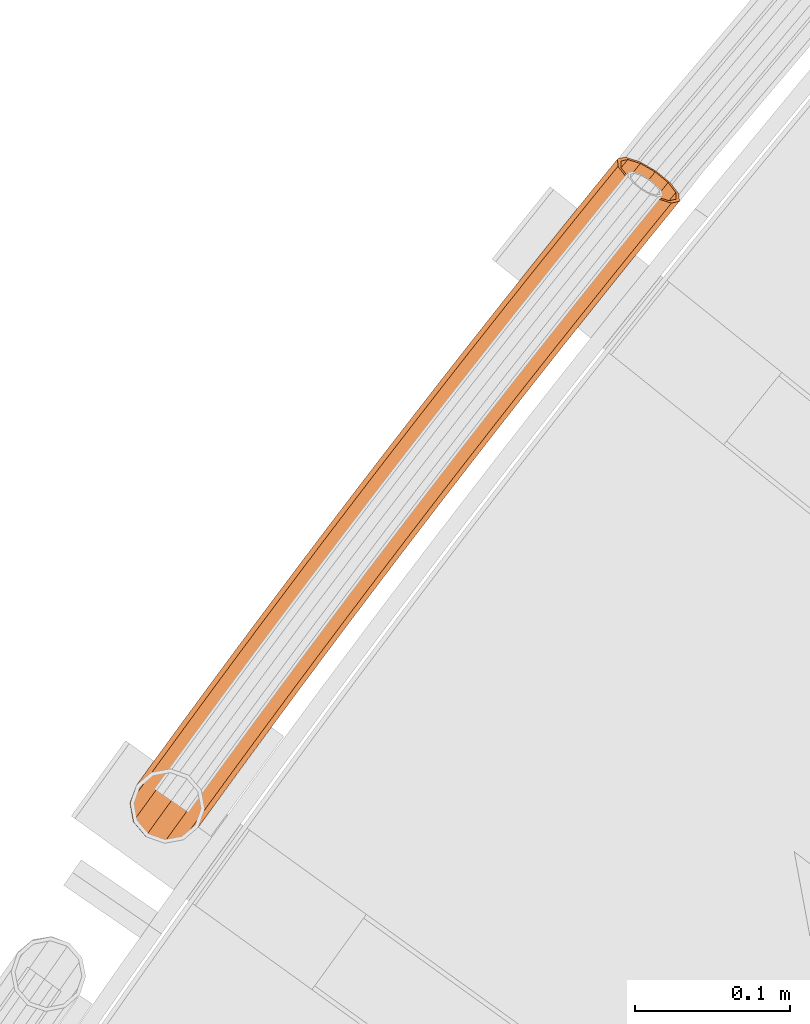
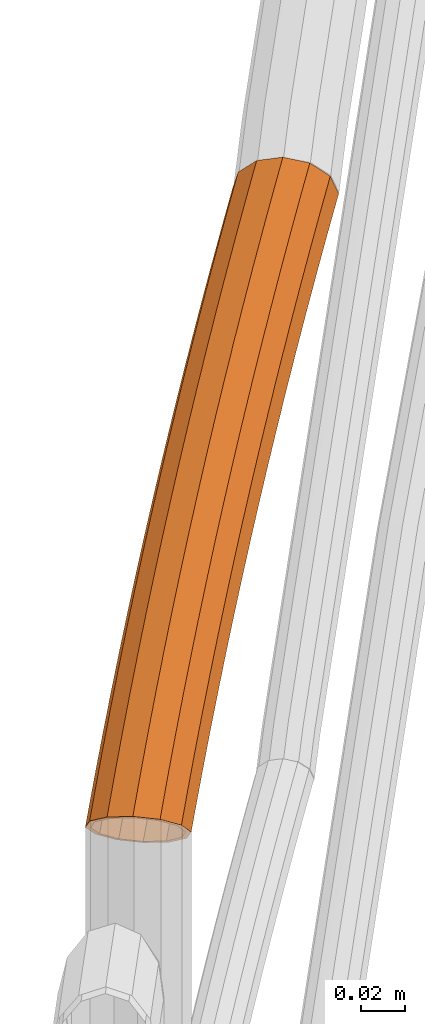
# One storey, part 65 of 126: 1 proxy.
"""IFC2X3 building model written with IfcOpenShell, lengths in millimetres."""

from ifc_helpers import new_model, si_unit, origin, origin_with_axes, place, context, project, spatial, faceted_brep, material, element, save


model = new_model("IFC2X3")

# Units and contexts
context_of_model_1 = context(None, 3, precision=0.1, world=origin())
context_of_model_2 = context(None, 3, precision=0.1, world=origin())
ifc_project = project(units=[si_unit("LENGTHUNIT", "METRE", prefix="MILLI"), si_unit("AREAUNIT", "SQUARE_METRE", prefix="CENTI"), si_unit("VOLUMEUNIT", "CUBIC_METRE", prefix="CENTI"), si_unit("MASSUNIT", "GRAM", prefix="KILO")], contexts=[context_of_model_1, context_of_model_2])

# Site, building, storey
site_placement = place(None, origin_with_axes())
site = spatial("IfcSite", under=ifc_project, at=site_placement, CompositionType="ELEMENT")
building_placement = place(site_placement, origin_with_axes())
building = spatial("IfcBuilding", under=site, at=building_placement, CompositionType="ELEMENT")
storey_placement = place(building_placement, origin_with_axes())
storey = spatial("IfcBuildingStorey", under=building, at=storey_placement, CompositionType="ELEMENT")

# Proxy
ifc_material = material(Name="S235JRG2")
proxy_placement = place(storey_placement, origin_with_axes())
element("IfcBuildingElementProxy", 1, at=proxy_placement, inside=storey, material=ifc_material, Name="HANDLAUF", context=context_of_model_2, shape_type="Brep", body=[
    faceted_brep([(824.6093, 13181.756, 9410.6145), (821.5899, 13177.553, 9410.6145), (828.7136, 13178.797, 9405.5548), (814.8145, 13188.818, 9413.85), (809.7472, 13181.763, 9413.85), (805.0197, 13195.879, 9410.6145), (801.6805, 13191.231, 9410.6145), (800.27, 13199.304, 9404.7592), (806.0336, 13195.148, 9408.4494), (803.9743, 13192.282, 9408.4494), (803.1045, 13197.26, 9404.8385), (814.8145, 13188.818, 9411.35), (811.206, 13183.794, 9411.35), (823.5954, 13182.487, 9408.4494), (821.8227, 13180.019, 9408.4494), (826.0049, 13180.75, 9405.479), (813.4129, 13228.076, 9389.7), (816.0308, 13226.175, 9377.625), (813.7213, 13222.983, 9377.625), (803.9729, 13215.031, 9389.7), (819.1362, 13223.92, 9373.787), (849.8756, 13201.594, 9377.625), (848.2081, 13199.29, 9377.625), (847.513, 13203.31, 9374.7051), (852.4935, 13199.693, 9389.7), (843.7948, 13187.672, 9389.7), (849.8756, 13201.594, 9401.775), (834.0464, 13179.719, 9401.775), (842.7233, 13206.789, 9410.6145), (832.9532, 13213.885, 9413.85), (823.1831, 13220.981, 9410.6145), (799.5596, 13203.413, 9401.775), (816.0308, 13226.175, 9401.775), (815.4357, 13226.607, 9389.7), (817.7826, 13224.903, 9400.525), (802.0776, 13203.199, 9400.525), (806.0341, 13213.615, 9389.7), (824.1945, 13220.246, 9408.4494), (832.9532, 13213.885, 9411.35), (841.7119, 13207.523, 9408.4494), (848.1238, 13202.867, 9400.525), (832.9944, 13181.959, 9400.525), (850.4707, 13201.162, 9389.7), (841.7337, 13189.088, 9389.7), (848.1238, 13202.867, 9378.875), (845.6901, 13199.504, 9378.875), (844.6755, 13205.371, 9374.6133), (817.7826, 13224.903, 9378.875), (814.7733, 13220.744, 9378.875), (821.8289, 13221.964, 9373.8741), (831.6887, 13253.148, 9389.7), (834.2999, 13251.237, 9377.625), (841.434, 13246.018, 9368.7855), (826.2076, 13225.13, 9368.7855), (851.1793, 13238.888, 9365.55), (838.0706, 13220.905, 9365.55), (860.9246, 13231.758, 9368.7855), (846.1204, 13211.449, 9368.7855), (868.0587, 13226.539, 9377.625), (870.6699, 13224.628, 9389.7), (868.0587, 13226.539, 9401.775), (860.9246, 13231.758, 9410.6145), (851.1793, 13238.888, 9413.85), (841.434, 13246.018, 9410.6145), (834.2999, 13251.237, 9401.775), (833.7064, 13251.672, 9389.7), (836.0473, 13249.959, 9400.525), (842.4428, 13245.28, 9408.4494), (851.1793, 13238.888, 9411.35), (859.9158, 13232.496, 9408.4494), (866.3113, 13227.817, 9400.525), (868.6523, 13226.104, 9389.7), (866.3113, 13227.817, 9378.875), (843.8138, 13210.407, 9370.9506), (859.9158, 13232.496, 9370.9506), (851.1793, 13238.888, 9368.05), (836.5974, 13218.884, 9368.05), (842.4428, 13245.28, 9370.9506), (825.9624, 13222.671, 9370.9506), (836.0473, 13249.959, 9378.875), (850.0519, 13278.155, 9389.7), (852.6564, 13276.236, 9377.625), (859.7722, 13270.992, 9368.7855), (869.4926, 13263.828, 9365.55), (879.2129, 13256.664, 9368.7855), (886.3287, 13251.42, 9377.625), (888.9333, 13249.5, 9389.7), (886.3287, 13251.42, 9401.775), (879.2129, 13256.664, 9410.6145), (869.4926, 13263.828, 9413.85), (859.7722, 13270.992, 9410.6145), (852.6564, 13276.236, 9401.775), (852.0643, 13276.672, 9389.7), (854.3993, 13274.951, 9400.525), (860.7785, 13270.25, 9408.4494), (869.4926, 13263.828, 9411.35), (878.2067, 13257.406, 9408.4494), (884.5858, 13252.704, 9400.525), (886.9208, 13250.983, 9389.7), (884.5858, 13252.704, 9378.875), (878.2067, 13257.406, 9370.9506), (869.4926, 13263.828, 9368.05), (860.7785, 13270.25, 9370.9506), (854.3993, 13274.951, 9378.875), (868.5022, 13303.099, 9389.7), (871.1, 13301.17, 9377.625), (878.1975, 13295.901, 9368.7855), (887.8928, 13288.703, 9365.55), (897.5881, 13281.505, 9368.7855), (904.6855, 13276.236, 9377.625), (907.2834, 13274.308, 9389.7), (904.6855, 13276.236, 9401.775), (897.5881, 13281.505, 9410.6145), (887.8928, 13288.703, 9413.85), (878.1975, 13295.901, 9410.6145), (871.1, 13301.17, 9401.775), (870.5095, 13301.609, 9389.7), (872.8384, 13299.879, 9400.525), (879.2011, 13295.156, 9408.4494), (887.8928, 13288.703, 9411.35), (896.5844, 13282.251, 9408.4494), (902.9471, 13277.527, 9400.525), (905.276, 13275.798, 9389.7), (902.9471, 13277.527, 9378.875), (896.5844, 13282.251, 9370.9506), (887.8928, 13288.703, 9368.05), (879.2011, 13295.156, 9370.9506), (872.8384, 13299.879, 9378.875), (887.0395, 13327.978, 9389.7), (889.6306, 13326.04, 9377.625), (896.7096, 13320.746, 9368.7855), (906.3797, 13313.514, 9365.55), (916.0498, 13306.283, 9368.7855), (923.1288, 13300.989, 9377.625), (925.7199, 13299.051, 9389.7), (923.1288, 13300.989, 9401.775), (916.0498, 13306.283, 9410.6145), (906.3797, 13313.514, 9413.85), (896.7096, 13320.746, 9410.6145), (889.6306, 13326.04, 9401.775), (889.0416, 13326.48, 9389.7), (891.3644, 13324.743, 9400.525), (897.7106, 13319.997, 9408.4494), (906.3797, 13313.514, 9411.35), (915.0488, 13307.031, 9408.4494), (921.395, 13302.286, 9400.525), (923.7178, 13300.549, 9389.7), (921.395, 13302.286, 9378.875), (915.0488, 13307.031, 9370.9506), (906.3797, 13313.514, 9368.05), (897.7106, 13319.997, 9370.9506), (891.3644, 13324.743, 9378.875), (905.6635, 13352.791, 9389.7), (908.2478, 13350.845, 9377.625), (915.3083, 13345.526, 9368.7855), (924.9531, 13338.261, 9365.55), (934.5979, 13330.996, 9368.7855), (941.6584, 13325.677, 9377.625), (944.2427, 13323.73, 9389.7), (941.6584, 13325.677, 9401.775), (934.5979, 13330.996, 9410.6145), (924.9531, 13338.261, 9413.85), (915.3083, 13345.526, 9410.6145), (908.2478, 13350.845, 9401.775), (907.6604, 13351.287, 9389.7), (909.9772, 13349.542, 9400.525), (916.3067, 13344.774, 9408.4494), (924.9531, 13338.261, 9411.35), (933.5995, 13331.748, 9408.4494), (939.9291, 13326.98, 9400.525), (942.2459, 13325.235, 9389.7), (939.9291, 13326.98, 9378.875), (933.5995, 13331.748, 9370.9506), (924.9531, 13338.261, 9368.05), (916.3067, 13344.774, 9370.9506), (909.9772, 13349.542, 9378.875), (924.374, 13377.54, 9389.7), (926.9515, 13375.584, 9377.625), (933.9934, 13370.241, 9368.7855), (943.6128, 13362.942, 9365.55), (953.2322, 13355.644, 9368.7855), (960.2741, 13350.3, 9377.625), (962.8516, 13348.345, 9389.7), (960.2741, 13350.3, 9401.775), (953.2322, 13355.644, 9410.6145), (943.6128, 13362.942, 9413.85), (933.9934, 13370.241, 9410.6145), (926.9515, 13375.584, 9401.775), (926.3656, 13376.029, 9389.7), (928.6763, 13374.276, 9400.525), (934.9892, 13369.486, 9408.4494), (943.6128, 13362.942, 9411.35), (952.2364, 13356.399, 9408.4494), (958.5493, 13351.609, 9400.525), (960.86, 13349.856, 9389.7), (958.5493, 13351.609, 9378.875), (952.2364, 13356.399, 9370.9506), (943.6128, 13362.942, 9368.05), (934.9892, 13369.486, 9370.9506), (928.6763, 13374.276, 9378.875), (943.1708, 13402.223, 9389.7), (945.7415, 13400.259, 9377.625), (952.7647, 13394.891, 9368.7855), (962.3585, 13387.559, 9365.55), (971.9524, 13380.226, 9368.7855), (978.9756, 13374.859, 9377.625), (981.5462, 13372.894, 9389.7), (978.9756, 13374.859, 9401.775), (971.9524, 13380.226, 9410.6145), (962.3585, 13387.559, 9413.85), (952.7647, 13394.891, 9410.6145), (945.7415, 13400.259, 9401.775), (945.1571, 13400.705, 9389.7), (947.4617, 13398.944, 9400.525), (953.7578, 13394.132, 9408.4494), (962.3585, 13387.559, 9411.35), (970.9592, 13380.985, 9408.4494), (977.2554, 13376.173, 9400.525), (979.5599, 13374.412, 9389.7), (977.2554, 13376.173, 9378.875), (970.9592, 13380.985, 9370.9506), (962.3585, 13387.559, 9368.05), (953.7578, 13394.132, 9370.9506), (947.4617, 13398.944, 9378.875), (962.0537, 13426.841, 9389.7), (964.6175, 13424.867, 9377.625), (971.6219, 13419.475, 9368.7855), (981.1901, 13412.109, 9365.55), (990.7583, 13404.743, 9368.7855), (997.7627, 13399.351, 9377.625), (1000.3265, 13397.378, 9389.7), (997.7627, 13399.351, 9401.775), (990.7583, 13404.743, 9410.6145), (981.1901, 13412.109, 9413.85), (971.6219, 13419.475, 9410.6145), (964.6175, 13424.867, 9401.775), (964.0347, 13425.316, 9389.7), (966.3331, 13423.547, 9400.525), (972.6124, 13418.713, 9408.4494), (981.1901, 13412.109, 9411.35), (989.7678, 13405.506, 9408.4494), (996.0471, 13400.672, 9400.525), (998.3455, 13398.903, 9389.7), (996.0471, 13400.672, 9378.875), (989.7678, 13405.506, 9370.9506), (981.1901, 13412.109, 9368.05), (972.6124, 13418.713, 9370.9506), (966.3331, 13423.547, 9378.875), (981.0223, 13451.392, 9389.7), (983.5792, 13449.41, 9377.625), (990.5648, 13443.993, 9368.7855), (1000.1072, 13436.594, 9365.55), (1009.6496, 13429.195, 9368.7855), (1016.6352, 13423.778, 9377.625), (1019.1921, 13421.796, 9389.7), (1016.6352, 13423.778, 9401.775), (1009.6496, 13429.195, 9410.6145), (1000.1072, 13436.594, 9413.85), (990.5648, 13443.993, 9410.6145), (983.5792, 13449.41, 9401.775), (982.998, 13449.86, 9389.7), (985.2902, 13448.083, 9400.525), (991.5526, 13443.227, 9408.4494), (1000.1072, 13436.594, 9411.35), (1008.6618, 13429.961, 9408.4494), (1014.9242, 13425.105, 9400.525), (1017.2164, 13423.327, 9389.7), (1014.9242, 13425.105, 9378.875), (1008.6618, 13429.961, 9370.9506), (1000.1072, 13436.594, 9368.05), (991.5526, 13443.227, 9370.9506), (985.2902, 13448.083, 9378.875), (1000.0766, 13475.877, 9389.7), (1002.6265, 13473.886, 9377.625), (1009.5931, 13468.445, 9368.7855), (1019.1097, 13461.012, 9365.55), (1028.6262, 13453.58, 9368.7855), (1035.5928, 13448.139, 9377.625), (1038.1428, 13446.147, 9389.7), (1035.5928, 13448.139, 9401.775), (1028.6262, 13453.58, 9410.6145), (1019.1097, 13461.012, 9413.85), (1009.5931, 13468.445, 9410.6145), (1002.6265, 13473.886, 9401.775), (1002.0469, 13474.339, 9389.7), (1004.3329, 13472.553, 9400.525), (1010.5783, 13467.675, 9408.4494), (1019.1097, 13461.012, 9411.35), (1027.6411, 13454.349, 9408.4494), (1033.8865, 13449.472, 9400.525), (1036.1725, 13447.686, 9389.7), (1033.8865, 13449.472, 9378.875), (1027.6411, 13454.349, 9370.9506), (1019.1097, 13461.012, 9368.05), (1010.5783, 13467.675, 9370.9506), (1004.3329, 13472.553, 9378.875), (1019.2162, 13500.296, 9389.7), (1021.7592, 13498.295, 9377.625), (1028.7067, 13492.83, 9368.7855), (1038.1973, 13485.365, 9365.55), (1047.6878, 13477.899, 9368.7855), (1054.6354, 13472.434, 9377.625), (1057.1784, 13470.433, 9389.7), (1054.6354, 13472.434, 9401.775), (1047.6878, 13477.899, 9410.6145), (1038.1973, 13485.365, 9413.85), (1028.7067, 13492.83, 9410.6145), (1021.7592, 13498.295, 9401.775), (1021.1811, 13498.75, 9389.7), (1023.4608, 13496.957, 9400.525), (1029.6892, 13492.057, 9408.4494), (1038.1973, 13485.365, 9411.35), (1046.7054, 13478.672, 9408.4494), (1052.9337, 13473.772, 9400.525), (1055.2134, 13471.979, 9389.7), (1052.9337, 13473.772, 9378.875), (1046.7054, 13478.672, 9370.9506), (1038.1973, 13485.365, 9368.05), (1029.6892, 13492.057, 9370.9506), (1023.4608, 13496.957, 9378.875), (1038.4409, 13524.647, 9389.7), (1040.9769, 13522.638, 9377.625), (1047.9053, 13517.148, 9368.7855), (1057.3698, 13509.65, 9365.55), (1066.8342, 13502.151, 9368.7855), (1073.7626, 13496.662, 9377.625), (1076.2986, 13494.652, 9389.7), (1073.7626, 13496.662, 9401.775), (1066.8342, 13502.151, 9410.6145), (1057.3698, 13509.65, 9413.85), (1047.9053, 13517.148, 9410.6145), (1040.9769, 13522.638, 9401.775), (1040.4004, 13523.095, 9389.7), (1042.6739, 13521.293, 9400.525), (1048.8851, 13516.372, 9408.4494), (1057.3698, 13509.65, 9411.35), (1065.8544, 13502.927, 9408.4494), (1072.0656, 13498.006, 9400.525), (1074.3391, 13496.205, 9389.7), (1072.0656, 13498.006, 9378.875), (1065.8544, 13502.927, 9370.9506), (1057.3698, 13509.65, 9368.05), (1048.8851, 13516.372, 9370.9506), (1042.6739, 13521.293, 9378.875), (1057.7505, 13548.931, 9389.7), (1060.2795, 13546.913, 9377.625), (1067.1887, 13541.4, 9368.7855), (1076.6269, 13533.868, 9365.55), (1086.0651, 13526.336, 9368.7855), (1092.9743, 13520.823, 9377.625), (1095.5033, 13518.805, 9389.7), (1092.9743, 13520.823, 9401.775), (1086.0651, 13526.336, 9410.6145), (1076.6269, 13533.868, 9413.85), (1067.1887, 13541.4, 9410.6145), (1060.2795, 13546.913, 9401.775), (1059.7046, 13547.372, 9389.7), (1061.9718, 13545.563, 9400.525), (1068.1658, 13540.62, 9408.4494), (1076.6269, 13533.868, 9411.35), (1085.0881, 13527.116, 9408.4494), (1091.282, 13522.173, 9400.525), (1093.5492, 13520.364, 9389.7), (1091.282, 13522.173, 9378.875), (1085.0881, 13527.116, 9370.9506), (1076.6269, 13533.868, 9368.05), (1068.1658, 13540.62, 9370.9506), (1061.9718, 13545.563, 9378.875), (1077.1448, 13573.148, 9389.7), (1079.6667, 13571.121, 9377.625), (1086.5566, 13565.584, 9368.7855), (1095.9685, 13558.019, 9365.55), (1105.3803, 13550.454, 9368.7855), (1112.2703, 13544.917, 9377.625), (1114.7921, 13542.89, 9389.7), (1112.2703, 13544.917, 9401.775), (1105.3803, 13550.454, 9410.6145), (1095.9685, 13558.019, 9413.85), (1086.5566, 13565.584, 9410.6145), (1079.6667, 13571.121, 9401.775), (1079.0934, 13571.582, 9389.7), (1081.3542, 13569.765, 9400.525), (1087.5309, 13564.8, 9408.4494), (1095.9685, 13558.019, 9411.35), (1104.406, 13551.237, 9408.4494), (1110.5827, 13546.273, 9400.525), (1112.8435, 13544.456, 9389.7), (1110.5827, 13546.273, 9378.875), (1104.406, 13551.237, 9370.9506), (1095.9685, 13558.019, 9368.05), (1087.5309, 13564.8, 9370.9506), (1081.3542, 13569.765, 9378.875), (1096.6235, 13597.297, 9389.7), (1099.1383, 13595.261, 9377.625), (1106.0088, 13589.7, 9368.7855), (1115.3942, 13582.102, 9365.55), (1124.7796, 13574.505, 9368.7855), (1131.6502, 13568.943, 9377.625), (1134.165, 13566.907, 9389.7), (1131.6502, 13568.943, 9401.775), (1124.7796, 13574.505, 9410.6145), (1115.3942, 13582.102, 9413.85), (1106.0088, 13589.7, 9410.6145), (1099.1383, 13595.261, 9401.775), (1098.5666, 13595.724, 9389.7), (1100.8211, 13593.899, 9400.525), (1106.9804, 13588.913, 9408.4494), (1115.3942, 13582.102, 9411.35), (1123.808, 13575.291, 9408.4494), (1129.9674, 13570.305, 9400.525), (1132.2218, 13568.48, 9389.7), (1129.9674, 13570.305, 9378.875), (1123.808, 13575.291, 9370.9506), (1115.3942, 13582.102, 9368.05), (1106.9804, 13588.913, 9370.9506), (1100.8211, 13593.899, 9378.875), (1114.6544, 13619.492, 9389.7), (1117.6732, 13620.165, 9382.5402), (1118.694, 13619.333, 9377.625), (1125.5451, 13613.747, 9368.7855), (1134.9039, 13606.117, 9365.55), (1144.2627, 13598.487, 9368.7855), (1151.1138, 13592.902, 9377.625), (1153.6215, 13590.857, 9389.7), (1152.6785, 13591.626, 9394.2409), (1149.5018, 13590.917, 9401.775), (1140.424, 13593.762, 9410.6145), (1129.792, 13599.825, 9413.85), (1120.4546, 13607.481, 9410.6145), (1114.9139, 13614.68, 9401.775), (1116.7216, 13618.072, 9389.7), (1116.9542, 13613.758, 9400.525), (1121.9214, 13607.305, 9408.4494), (1130.2922, 13600.441, 9411.35), (1139.8235, 13595.005, 9408.4494), (1147.9616, 13592.455, 9400.525), (1150.8666, 13593.103, 9393.6353), (1151.6839, 13592.437, 9389.7), (1149.4358, 13594.27, 9378.875), (1143.2939, 13599.277, 9370.9506), (1134.9039, 13606.117, 9368.05), (1126.5139, 13612.958, 9370.9506), (1120.372, 13617.965, 9378.875), (1119.4851, 13618.688, 9383.1458), (1119.7505, 13620.624, 9377.625), (1128.8385, 13617.773, 9368.7855), (1139.4763, 13611.706, 9365.55), (1148.8136, 13604.049, 9368.7855), (1154.3483, 13596.855, 9377.625), (1154.5975, 13592.05, 9389.7), (1152.5297, 13593.471, 9389.7), (1152.3063, 13597.778, 9378.875), (1147.3445, 13604.228, 9370.9506), (1138.9739, 13611.092, 9368.05), (1129.4373, 13616.53, 9370.9506), (1121.29, 13619.087, 9378.875)], [[[0, 1, 2]], [[0, 3, 4, 1]], [[3, 5, 6, 4]], [[5, 7, 6]], [[8, 9, 10]], [[8, 11, 12, 9]], [[11, 13, 14, 12]], [[13, 15, 14]], [[16, 17, 18, 19]], [[17, 20, 18]], [[21, 22, 23]], [[21, 24, 25, 22]], [[24, 26, 27, 25]], [[0, 2, 27, 26, 28]], [[0, 28, 29, 3]], [[3, 29, 30, 5]], [[31, 7, 5, 30, 32]], [[16, 19, 31, 32]], [[33, 34, 35, 36]], [[35, 34, 37, 8, 10]], [[8, 37, 38, 11]], [[11, 38, 39, 13]], [[13, 39, 40, 41, 15]], [[40, 42, 43, 41]], [[42, 44, 45, 43]], [[44, 46, 45]], [[47, 48, 49]], [[33, 36, 48, 47]], [[16, 50, 51, 17]], [[17, 51, 52, 53, 20]], [[52, 54, 55, 53]], [[54, 56, 57, 55]], [[57, 56, 58, 21, 23]], [[21, 58, 59, 24]], [[24, 59, 60, 26]], [[26, 60, 61, 28]], [[28, 61, 62, 29]], [[29, 62, 63, 30]], [[30, 63, 64, 32]], [[32, 64, 50, 16]], [[33, 65, 66, 34]], [[34, 66, 67, 37]], [[37, 67, 68, 38]], [[38, 68, 69, 39]], [[39, 69, 70, 40]], [[40, 70, 71, 42]], [[42, 71, 72, 44]], [[73, 46, 44, 72, 74]], [[74, 75, 76, 73]], [[75, 77, 78, 76]], [[47, 49, 78, 77, 79]], [[47, 79, 65, 33]], [[50, 80, 81, 51]], [[51, 81, 82, 52]], [[52, 82, 83, 54]], [[54, 83, 84, 56]], [[56, 84, 85, 58]], [[58, 85, 86, 59]], [[59, 86, 87, 60]], [[60, 87, 88, 61]], [[61, 88, 89, 62]], [[62, 89, 90, 63]], [[63, 90, 91, 64]], [[64, 91, 80, 50]], [[65, 92, 93, 66]], [[66, 93, 94, 67]], [[67, 94, 95, 68]], [[68, 95, 96, 69]], [[69, 96, 97, 70]], [[70, 97, 98, 71]], [[71, 98, 99, 72]], [[72, 99, 100, 74]], [[74, 100, 101, 75]], [[75, 101, 102, 77]], [[77, 102, 103, 79]], [[79, 103, 92, 65]], [[80, 104, 105, 81]], [[81, 105, 106, 82]], [[82, 106, 107, 83]], [[83, 107, 108, 84]], [[84, 108, 109, 85]], [[85, 109, 110, 86]], [[86, 110, 111, 87]], [[87, 111, 112, 88]], [[88, 112, 113, 89]], [[89, 113, 114, 90]], [[90, 114, 115, 91]], [[91, 115, 104, 80]], [[92, 116, 117, 93]], [[93, 117, 118, 94]], [[94, 118, 119, 95]], [[95, 119, 120, 96]], [[96, 120, 121, 97]], [[97, 121, 122, 98]], [[98, 122, 123, 99]], [[99, 123, 124, 100]], [[100, 124, 125, 101]], [[101, 125, 126, 102]], [[102, 126, 127, 103]], [[103, 127, 116, 92]], [[104, 128, 129, 105]], [[105, 129, 130, 106]], [[106, 130, 131, 107]], [[107, 131, 132, 108]], [[108, 132, 133, 109]], [[109, 133, 134, 110]], [[110, 134, 135, 111]], [[111, 135, 136, 112]], [[112, 136, 137, 113]], [[113, 137, 138, 114]], [[114, 138, 139, 115]], [[115, 139, 128, 104]], [[116, 140, 141, 117]], [[117, 141, 142, 118]], [[118, 142, 143, 119]], [[119, 143, 144, 120]], [[120, 144, 145, 121]], [[121, 145, 146, 122]], [[122, 146, 147, 123]], [[123, 147, 148, 124]], [[124, 148, 149, 125]], [[125, 149, 150, 126]], [[126, 150, 151, 127]], [[127, 151, 140, 116]], [[128, 152, 153, 129]], [[129, 153, 154, 130]], [[130, 154, 155, 131]], [[131, 155, 156, 132]], [[132, 156, 157, 133]], [[133, 157, 158, 134]], [[134, 158, 159, 135]], [[135, 159, 160, 136]], [[136, 160, 161, 137]], [[137, 161, 162, 138]], [[138, 162, 163, 139]], [[139, 163, 152, 128]], [[140, 164, 165, 141]], [[141, 165, 166, 142]], [[142, 166, 167, 143]], [[143, 167, 168, 144]], [[144, 168, 169, 145]], [[145, 169, 170, 146]], [[146, 170, 171, 147]], [[147, 171, 172, 148]], [[148, 172, 173, 149]], [[149, 173, 174, 150]], [[150, 174, 175, 151]], [[151, 175, 164, 140]], [[152, 176, 177, 153]], [[153, 177, 178, 154]], [[154, 178, 179, 155]], [[155, 179, 180, 156]], [[156, 180, 181, 157]], [[157, 181, 182, 158]], [[158, 182, 183, 159]], [[159, 183, 184, 160]], [[160, 184, 185, 161]], [[161, 185, 186, 162]], [[162, 186, 187, 163]], [[163, 187, 176, 152]], [[164, 188, 189, 165]], [[165, 189, 190, 166]], [[166, 190, 191, 167]], [[167, 191, 192, 168]], [[168, 192, 193, 169]], [[169, 193, 194, 170]], [[170, 194, 195, 171]], [[171, 195, 196, 172]], [[172, 196, 197, 173]], [[173, 197, 198, 174]], [[174, 198, 199, 175]], [[175, 199, 188, 164]], [[176, 200, 201, 177]], [[177, 201, 202, 178]], [[178, 202, 203, 179]], [[179, 203, 204, 180]], [[180, 204, 205, 181]], [[181, 205, 206, 182]], [[182, 206, 207, 183]], [[183, 207, 208, 184]], [[184, 208, 209, 185]], [[185, 209, 210, 186]], [[186, 210, 211, 187]], [[187, 211, 200, 176]], [[188, 212, 213, 189]], [[189, 213, 214, 190]], [[190, 214, 215, 191]], [[191, 215, 216, 192]], [[192, 216, 217, 193]], [[193, 217, 218, 194]], [[194, 218, 219, 195]], [[195, 219, 220, 196]], [[196, 220, 221, 197]], [[197, 221, 222, 198]], [[198, 222, 223, 199]], [[199, 223, 212, 188]], [[200, 224, 225, 201]], [[201, 225, 226, 202]], [[202, 226, 227, 203]], [[203, 227, 228, 204]], [[204, 228, 229, 205]], [[205, 229, 230, 206]], [[206, 230, 231, 207]], [[207, 231, 232, 208]], [[208, 232, 233, 209]], [[209, 233, 234, 210]], [[210, 234, 235, 211]], [[211, 235, 224, 200]], [[212, 236, 237, 213]], [[213, 237, 238, 214]], [[214, 238, 239, 215]], [[215, 239, 240, 216]], [[216, 240, 241, 217]], [[217, 241, 242, 218]], [[218, 242, 243, 219]], [[219, 243, 244, 220]], [[220, 244, 245, 221]], [[221, 245, 246, 222]], [[222, 246, 247, 223]], [[223, 247, 236, 212]], [[224, 248, 249, 225]], [[225, 249, 250, 226]], [[226, 250, 251, 227]], [[227, 251, 252, 228]], [[228, 252, 253, 229]], [[229, 253, 254, 230]], [[230, 254, 255, 231]], [[231, 255, 256, 232]], [[232, 256, 257, 233]], [[233, 257, 258, 234]], [[234, 258, 259, 235]], [[235, 259, 248, 224]], [[236, 260, 261, 237]], [[237, 261, 262, 238]], [[238, 262, 263, 239]], [[239, 263, 264, 240]], [[240, 264, 265, 241]], [[241, 265, 266, 242]], [[242, 266, 267, 243]], [[243, 267, 268, 244]], [[244, 268, 269, 245]], [[245, 269, 270, 246]], [[246, 270, 271, 247]], [[247, 271, 260, 236]], [[248, 272, 273, 249]], [[249, 273, 274, 250]], [[250, 274, 275, 251]], [[251, 275, 276, 252]], [[252, 276, 277, 253]], [[253, 277, 278, 254]], [[254, 278, 279, 255]], [[255, 279, 280, 256]], [[256, 280, 281, 257]], [[257, 281, 282, 258]], [[258, 282, 283, 259]], [[259, 283, 272, 248]], [[260, 284, 285, 261]], [[261, 285, 286, 262]], [[262, 286, 287, 263]], [[263, 287, 288, 264]], [[264, 288, 289, 265]], [[265, 289, 290, 266]], [[266, 290, 291, 267]], [[267, 291, 292, 268]], [[268, 292, 293, 269]], [[269, 293, 294, 270]], [[270, 294, 295, 271]], [[271, 295, 284, 260]], [[272, 296, 297, 273]], [[273, 297, 298, 274]], [[274, 298, 299, 275]], [[275, 299, 300, 276]], [[276, 300, 301, 277]], [[277, 301, 302, 278]], [[278, 302, 303, 279]], [[279, 303, 304, 280]], [[280, 304, 305, 281]], [[281, 305, 306, 282]], [[282, 306, 307, 283]], [[283, 307, 296, 272]], [[284, 308, 309, 285]], [[285, 309, 310, 286]], [[286, 310, 311, 287]], [[287, 311, 312, 288]], [[288, 312, 313, 289]], [[289, 313, 314, 290]], [[290, 314, 315, 291]], [[291, 315, 316, 292]], [[292, 316, 317, 293]], [[293, 317, 318, 294]], [[294, 318, 319, 295]], [[295, 319, 308, 284]], [[296, 320, 321, 297]], [[297, 321, 322, 298]], [[298, 322, 323, 299]], [[299, 323, 324, 300]], [[300, 324, 325, 301]], [[301, 325, 326, 302]], [[302, 326, 327, 303]], [[303, 327, 328, 304]], [[304, 328, 329, 305]], [[305, 329, 330, 306]], [[306, 330, 331, 307]], [[307, 331, 320, 296]], [[308, 332, 333, 309]], [[309, 333, 334, 310]], [[310, 334, 335, 311]], [[311, 335, 336, 312]], [[312, 336, 337, 313]], [[313, 337, 338, 314]], [[314, 338, 339, 315]], [[315, 339, 340, 316]], [[316, 340, 341, 317]], [[317, 341, 342, 318]], [[318, 342, 343, 319]], [[319, 343, 332, 308]], [[320, 344, 345, 321]], [[321, 345, 346, 322]], [[322, 346, 347, 323]], [[323, 347, 348, 324]], [[324, 348, 349, 325]], [[325, 349, 350, 326]], [[326, 350, 351, 327]], [[327, 351, 352, 328]], [[328, 352, 353, 329]], [[329, 353, 354, 330]], [[330, 354, 355, 331]], [[331, 355, 344, 320]], [[332, 356, 357, 333]], [[333, 357, 358, 334]], [[334, 358, 359, 335]], [[335, 359, 360, 336]], [[336, 360, 361, 337]], [[337, 361, 362, 338]], [[338, 362, 363, 339]], [[339, 363, 364, 340]], [[340, 364, 365, 341]], [[341, 365, 366, 342]], [[342, 366, 367, 343]], [[343, 367, 356, 332]], [[344, 368, 369, 345]], [[345, 369, 370, 346]], [[346, 370, 371, 347]], [[347, 371, 372, 348]], [[348, 372, 373, 349]], [[349, 373, 374, 350]], [[350, 374, 375, 351]], [[351, 375, 376, 352]], [[352, 376, 377, 353]], [[353, 377, 378, 354]], [[354, 378, 379, 355]], [[355, 379, 368, 344]], [[356, 380, 381, 357]], [[357, 381, 382, 358]], [[358, 382, 383, 359]], [[359, 383, 384, 360]], [[360, 384, 385, 361]], [[361, 385, 386, 362]], [[362, 386, 387, 363]], [[363, 387, 388, 364]], [[364, 388, 389, 365]], [[365, 389, 390, 366]], [[366, 390, 391, 367]], [[367, 391, 380, 356]], [[368, 392, 393, 369]], [[369, 393, 394, 370]], [[370, 394, 395, 371]], [[371, 395, 396, 372]], [[372, 396, 397, 373]], [[373, 397, 398, 374]], [[374, 398, 399, 375]], [[375, 399, 400, 376]], [[376, 400, 401, 377]], [[377, 401, 402, 378]], [[378, 402, 403, 379]], [[379, 403, 392, 368]], [[380, 404, 405, 381]], [[381, 405, 406, 382]], [[382, 406, 407, 383]], [[383, 407, 408, 384]], [[384, 408, 409, 385]], [[385, 409, 410, 386]], [[386, 410, 411, 387]], [[387, 411, 412, 388]], [[388, 412, 413, 389]], [[389, 413, 414, 390]], [[390, 414, 415, 391]], [[391, 415, 404, 380]], [[392, 416, 417, 418, 393]], [[393, 418, 419, 394]], [[394, 419, 420, 395]], [[395, 420, 421, 396]], [[396, 421, 422, 397]], [[397, 422, 423, 398]], [[399, 398, 423, 424, 425]], [[399, 425, 426, 400]], [[400, 426, 427, 401]], [[401, 427, 428, 402]], [[402, 428, 429, 403]], [[392, 403, 429, 416]], [[404, 430, 431, 405]], [[405, 431, 432, 406]], [[406, 432, 433, 407]], [[407, 433, 434, 408]], [[408, 434, 435, 409]], [[409, 435, 436, 437, 410]], [[410, 437, 438, 411]], [[411, 438, 439, 412]], [[412, 439, 440, 413]], [[413, 440, 441, 414]], [[414, 441, 442, 415]], [[404, 415, 442, 443, 430]], [[417, 444, 418]], [[418, 444, 445, 419]], [[419, 445, 446, 420]], [[420, 446, 447, 421]], [[421, 447, 448, 422]], [[422, 448, 449, 423]], [[423, 449, 424]], [[436, 450, 437]], [[437, 450, 451, 438]], [[438, 451, 452, 439]], [[439, 452, 453, 440]], [[440, 453, 454, 441]], [[441, 454, 455, 442]], [[442, 455, 443]], [[19, 18, 20, 53, 55, 57, 23, 22, 25, 27, 2, 1, 4, 6, 7, 31], [9, 12, 14, 15, 41, 43, 45, 46, 73, 76, 78, 49, 48, 36, 35, 10]], [[416, 429, 428, 427, 426, 425, 424, 449, 448, 447, 446, 445, 444, 417], [430, 443, 455, 454, 453, 452, 451, 450, 436, 435, 434, 433, 432, 431]]]),
])

save(model, "model.ifc")
